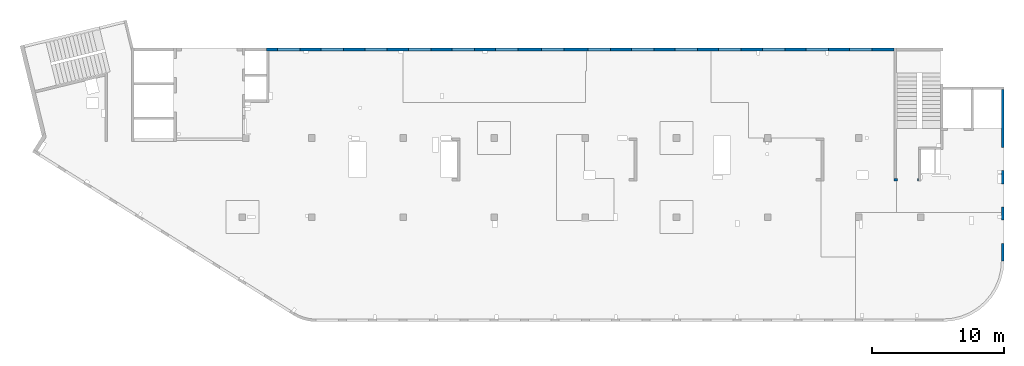
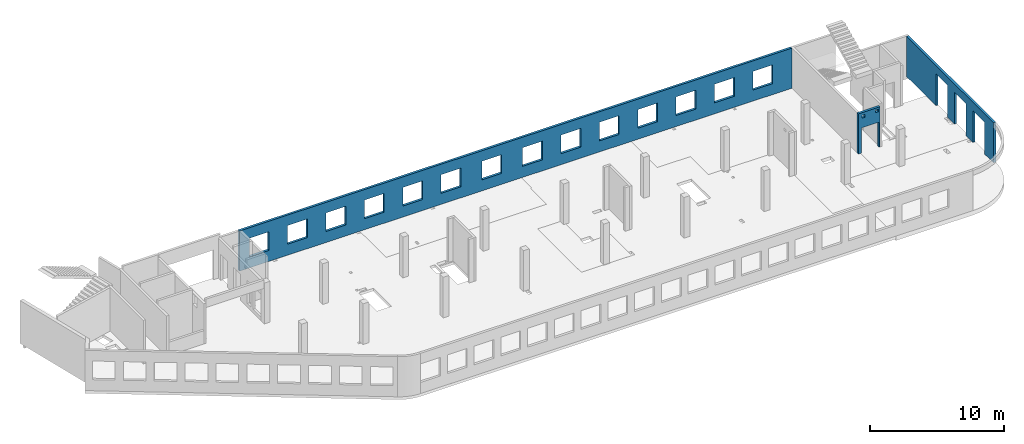
# One storey, part 6 of 6: 3 walls, 20 openings.
"""IFC4 building model written with IfcOpenShell, lengths in millimetres."""

from ifc_helpers import new_model, entity, si_unit, converted_unit, derived_unit, direction, frame, origin, place, context, subcontext, project, spatial, indexed_curve, outline, extrude, polygons, material, type_object, element, save


model = new_model("IFC4")

# Units and contexts
model_context = context("Model", 3, precision=0.01, world=origin(), true_north=direction((6.12303176911189e-17, 1.0)))
plan_context = context("Plan", 3, precision=0.01, world=origin(), true_north=direction((6.12303176911189e-17, 1.0)))
body_context = subcontext(model_context, "Body", "Model", "MODEL_VIEW")
ifc_project = project(units=[si_unit("LENGTHUNIT", "METRE", prefix="MILLI"), si_unit("AREAUNIT", "SQUARE_METRE"), si_unit("VOLUMEUNIT", "CUBIC_METRE"), converted_unit("PLANEANGLEUNIT", "DEGREE", entity("IfcRatioMeasure", 0.0174532925199433), si_unit("PLANEANGLEUNIT", "RADIAN"), dimensions=[0, 0, 0, 0, 0, 0, 0]), si_unit("MASSUNIT", "GRAM", prefix="KILO"), derived_unit("MASSDENSITYUNIT", [(si_unit("MASSUNIT", "GRAM", prefix="KILO"), 1), (si_unit("LENGTHUNIT", "METRE"), -3)]), derived_unit("MOMENTOFINERTIAUNIT", [(si_unit("LENGTHUNIT", "METRE"), 4)]), si_unit("TIMEUNIT", "SECOND"), si_unit("FREQUENCYUNIT", "HERTZ"), si_unit("THERMODYNAMICTEMPERATUREUNIT", "DEGREE_CELSIUS"), derived_unit("THERMALTRANSMITTANCEUNIT", [(si_unit("MASSUNIT", "GRAM", prefix="KILO"), 1), (si_unit("THERMODYNAMICTEMPERATUREUNIT", "KELVIN"), -1), (si_unit("TIMEUNIT", "SECOND"), -3)]), derived_unit("VOLUMETRICFLOWRATEUNIT", [(si_unit("LENGTHUNIT", "METRE"), 3), (si_unit("TIMEUNIT", "SECOND"), -1)]), derived_unit("MASSFLOWRATEUNIT", [(si_unit("MASSUNIT", "GRAM", prefix="KILO"), 1), (si_unit("TIMEUNIT", "SECOND"), -1)]), derived_unit("ROTATIONALFREQUENCYUNIT", [(si_unit("TIMEUNIT", "SECOND"), -1)]), si_unit("ELECTRICCURRENTUNIT", "AMPERE"), si_unit("ELECTRICVOLTAGEUNIT", "VOLT"), si_unit("POWERUNIT", "WATT"), si_unit("FORCEUNIT", "NEWTON", prefix="KILO"), si_unit("ILLUMINANCEUNIT", "LUX"), si_unit("LUMINOUSFLUXUNIT", "LUMEN"), si_unit("LUMINOUSINTENSITYUNIT", "CANDELA"), derived_unit("USERDEFINED", [(si_unit("MASSUNIT", "GRAM", prefix="KILO"), -1), (si_unit("LENGTHUNIT", "METRE"), -2), (si_unit("TIMEUNIT", "SECOND"), 3), (si_unit("LUMINOUSFLUXUNIT", "LUMEN"), 1)]), derived_unit("LINEARVELOCITYUNIT", [(si_unit("LENGTHUNIT", "METRE"), 1), (si_unit("TIMEUNIT", "SECOND"), -1)]), si_unit("PRESSUREUNIT", "PASCAL"), derived_unit("USERDEFINED", [(si_unit("LENGTHUNIT", "METRE"), -2), (si_unit("MASSUNIT", "GRAM", prefix="KILO"), 1), (si_unit("TIMEUNIT", "SECOND"), -2)]), derived_unit("LINEARFORCEUNIT", [(si_unit("MASSUNIT", "GRAM", prefix="KILO"), 1), (si_unit("LENGTHUNIT", "METRE"), 1), (si_unit("TIMEUNIT", "SECOND"), -2), (si_unit("LENGTHUNIT", "METRE"), -1)]), derived_unit("PLANARFORCEUNIT", [(si_unit("MASSUNIT", "GRAM", prefix="KILO"), 1), (si_unit("LENGTHUNIT", "METRE"), 1), (si_unit("TIMEUNIT", "SECOND"), -2), (si_unit("LENGTHUNIT", "METRE"), -2)])], contexts=[model_context, plan_context])

# Site, building, storey
site_placement = place(None, origin())
site = spatial("IfcSite", under=ifc_project, at=site_placement, CompositionType="ELEMENT")
building_placement = place(site_placement, origin())
building = spatial("IfcBuilding", under=site, at=building_placement, CompositionType="ELEMENT")
storey_placement = place(building_placement, frame((0.0, 0.0, 8100.0)))
storey = spatial("IfcBuildingStorey", under=building, at=storey_placement, CompositionType="ELEMENT", Elevation=8100.0)

# Wall, openings
ifc_material = material()
wall_type = type_object("IfcWallType", PredefinedType="STANDARD")
wall_1_placement = place(storey_placement, frame((73469.9994506836, 17369.9992263554, -150.0), z_axis=(0.0, 0.0, 1.0), x_axis=(0.0, -1.0, 0.0)))
wall_1 = element("IfcWall", 1, at=wall_1_placement, inside=storey, type_object=wall_type, material=ifc_material, PredefinedType="NOTDEFINED", context=body_context, shape_type="Tessellation", body=[
    polygons([(12970.0, -99.9999999999918, 0.0), (12970.0, -99.9999999999918, 3200.0), (12970.0, -99.9999999999918, 3650.0), (9560.00000000002, -99.9999999999877, 3650.0), (9360.00000000002, -99.999999999988, 3650.0), (7085.00000000004, -99.999999999991, 3650.0), (6485.00000000003, -99.9999999999918, 3650.0), (6320.00000000002, -99.999999999992, 3650.0), (6120.00000000002, -99.9999999999923, 3650.0), (0.0, -99.9999999999831, 3650.0), (0.0, -99.9999999999831, 0.0), (4394.99999999951, -99.9999999999946, 0.0), (4394.99999999951, -100.000000000315, 2900.0), (6144.99999999951, -100.000000000313, 2900.0), (6144.99999999951, -99.9999999999923, 0.0), (6319.99895780055, -99.999999999992, 0.0), (6485.00000000002, -99.9999999999918, 0.0), (7084.99895780057, -99.999999999991, 0.0), (7144.99999999951, -99.9999999999909, 0.0), (7144.99999999951, -100.000000000311, 2900.0), (8894.99999999951, -100.000000000309, 2900.0), (8894.99999999951, -99.9999999999886, 0.0), (9895.00000000005, -99.9999999999959, 0.0), (9895.00000000005, -99.9999999999959, 2900.0), (11645.0, -99.9999999999936, 2900.0), (11645.0, -99.9999999999936, 0.0), (12970.0, 100.000000000006, 3650.0), (12970.0, 100.000000000006, 3200.0), (12970.0, 100.000000000006, 0.0), (11645.0, 100.000000000004, 0.0), (11645.0, 100.000000000316, 2900.0), (9895.00000000005, 100.000000000314, 2900.0), (9895.00000000004, 100.000000000002, 0.0), (8894.99999999951, 100.000000000001, 0.0), (8894.99999999951, 100.000000000001, 2900.0), (7144.99999999951, 99.9999999999983, 2900.0), (7144.99999999951, 99.9999999999983, 0.0), (6144.99999999951, 99.9999999999969, 0.0), (6144.99999999951, 99.9999999999969, 2900.0), (4394.99999999951, 99.9999999999946, 2900.0), (4394.99999999951, 99.9999999999946, 0.0), (0.0, 100.000000000006, 0.0), (0.0, 100.000000000006, 3650.0)], [[[1, 2, 3, 4, 5, 6, 7, 8, 9, 10, 11, 12, 13, 14, 15, 16, 17, 18, 19, 20, 21, 22, 23, 24, 25, 26]], [[27, 28, 29, 30, 31, 32, 33, 34, 35, 36, 37, 38, 39, 40, 41, 42, 43]], [[11, 42, 41, 12]], [[3, 2, 1, 29, 28, 27]], [[10, 9, 8, 7, 6, 5, 4, 3, 27, 43]], [[11, 10, 43, 42]], [[24, 32, 31, 25]], [[32, 24, 23, 33]], [[25, 31, 30, 26]], [[35, 21, 20, 36]], [[21, 35, 34, 22]], [[36, 20, 19, 37]], [[39, 14, 13, 40]], [[14, 39, 38, 15]], [[40, 13, 12, 41]], [[37, 19, 18, 17, 16, 15, 38]], [[33, 23, 22, 34]], [[29, 1, 26, 30]]], closed=True),
])
opening_1_placement = place(wall_1_placement, frame((17369.9992263554, -73469.9994506836, 150.0), z_axis=(0.0, 0.0, 1.0), x_axis=(0.0, 1.0, 0.0)))
element("IfcOpeningElement", 2, at=opening_1_placement, cuts=wall_1, PredefinedType="OPENING", context=body_context, shape_type="SweptSolid", body=[
    extrude(outline(indexed_curve([(-1449.99999999999, -874.999999999999), (1449.99999999999, -874.999999999999), (1449.99999999999, 875.0), (-1449.99999999999, 875.0), (-1449.99999999999, -874.999999999999)], self_intersect=False)), frame((73369.9994506836, 6599.9992263554, 1300.0), z_axis=(1.0, 0.0, 0.0), x_axis=(0.0, 0.0, -1.0)), (0.0, 0.0, 1.0), 200.000000000968),
])
opening_2_placement = place(wall_1_placement, frame((17369.9992263554, -73469.9994506836, 150.0), z_axis=(0.0, 0.0, 1.0), x_axis=(0.0, 1.0, 0.0)))
element("IfcOpeningElement", 3, at=opening_2_placement, cuts=wall_1, PredefinedType="OPENING", context=body_context, shape_type="SweptSolid", body=[
    extrude(outline(indexed_curve([(-874.999999999999, -1449.99999999999), (874.999999999999, -1449.99999999999), (874.999999999999, 1450.0), (-874.999999999999, 1450.0), (-874.999999999999, -1449.99999999999)], self_intersect=False)), frame((73369.9994506826, 9349.99922635594, 1300.0), z_axis=(1.0, 0.0, 0.0), x_axis=(0.0, -1.0, 0.0)), (0.0, 0.0, 1.0), 200.000000000968),
])
opening_3_placement = place(wall_1_placement, frame((17369.9992263554, -73469.9994506836, 150.0), z_axis=(0.0, 0.0, 1.0), x_axis=(0.0, 1.0, 0.0)))
element("IfcOpeningElement", 4, at=opening_3_placement, cuts=wall_1, PredefinedType="OPENING", context=body_context, shape_type="SweptSolid", body=[
    extrude(outline(indexed_curve([(-875.0, -1449.99999999999), (874.999999999998, -1449.99999999999), (874.999999999998, 1450.0), (-875.0, 1450.0), (-875.0, -1449.99999999999)], self_intersect=False)), frame((73369.9994506826, 12099.9992263559, 1300.0), z_axis=(1.0, 0.0, 0.0), x_axis=(0.0, -1.0, 0.0)), (0.0, 0.0, 1.0), 200.000000000968),
])

wall_2_placement = place(storey_placement, frame((67080.0002685547, 10524.9992263555, -150.0), z_axis=(0.0, 0.0, 1.0), x_axis=(-1.0, 0.0, 0.0)))
wall_2 = element("IfcWall", 5, at=wall_2_placement, inside=storey, type_object=wall_type, material=ifc_material, PredefinedType="NOTDEFINED", context=body_context, shape_type="Tessellation", body=[
    polygons([(1849.99999999999, -100.000000000001, 3650.0), (1650.0, -100.000000000003, 3650.0), (-9.772240076716e-13, -100.000000000001, 3650.0), (-9.772240076716e-13, -100.000000000001, 0.0), (74.9999999999906, -100.000000000001, 0.0), (74.9999999999906, -100.000000000001, 2279.99999999805), (1575.0, -100.000000000001, 2279.99999999804), (1575.0, -100.000000000003, 0.0), (1650.0, -100.000000000003, 0.0), (1849.99999999999, -100.000000000001, 0.0), (125.000000000014, -100.000000000322, 3490.0), (375.000000000009, -100.000000000324, 3490.0), (375.000000000009, -100.000000000324, 3240.00000000001), (125.000000000014, -100.000000000322, 3240.00000000001), (1275.0, -100.000000000322, 3400.0), (1524.99999999999, -100.000000000322, 3400.0), (1524.99999999999, -100.000000000322, 3150.00000000001), (1275.0, -100.000000000322, 3150.00000000001), (-1.61109744921212e-12, 99.9999999999989, 3650.0), (1849.99999999999, 99.9999999999989, 3650.0), (1849.99999999999, 99.9999999999989, 0.0), (1575.0, 99.9999999999968, 0.0), (1575.0, 99.9999999999968, 2279.99999999804), (74.99999999999, 99.9999999999989, 2279.99999999805), (74.99999999999, 99.9999999999989, 0.0), (-1.61109744921212e-12, 99.9999999999989, 0.0), (375.000000000008, 99.9999999999968, 3490.0), (125.000000000013, 99.9999999999968, 3490.0), (125.000000000013, 99.9999999999968, 3240.00000000001), (375.000000000008, 99.9999999999968, 3240.00000000001), (1524.99999999999, 99.9999999999968, 3400.0), (1275.0, 99.9999999999989, 3400.0), (1275.0, 99.9999999999989, 3150.00000000001), (1524.99999999999, 99.9999999999968, 3150.00000000001)], [[[1, 2, 3, 4, 5, 6, 7, 8, 9, 10], [11, 12, 13, 14], [15, 16, 17, 18]], [[19, 20, 21, 22, 23, 24, 25, 26], [27, 28, 29, 30], [31, 32, 33, 34]], [[4, 26, 25, 5]], [[3, 2, 1, 20, 19]], [[4, 3, 19, 26]], [[1, 10, 21, 20]], [[12, 11, 28, 27]], [[12, 27, 30, 13]], [[13, 30, 29, 14]], [[28, 11, 14, 29]], [[16, 15, 32, 31]], [[16, 31, 34, 17]], [[17, 34, 33, 18]], [[32, 15, 18, 33]], [[6, 24, 23, 7]], [[7, 23, 22, 8]], [[24, 6, 5, 25]], [[21, 10, 9, 8, 22]]], closed=True),
])
opening_4_placement = place(wall_2_placement, frame((67080.0002685547, 10524.9992263555, 150.0), z_axis=(0.0, 0.0, 1.0), x_axis=(-1.0, 0.0, 0.0)))
element("IfcOpeningElement", 6, at=opening_4_placement, cuts=wall_2, PredefinedType="OPENING", context=body_context, shape_type="SweptSolid", body=[
    extrude(outline(indexed_curve([(-750.000000000003, -1139.99999999902), (749.999999999994, -1139.99999999902), (749.999999999994, 1139.99999999902), (-750.000000000003, 1139.99999999902), (-750.000000000003, -1139.99999999902)], self_intersect=False)), frame((66255.0002685547, 10724.9992263575, 990.0), z_axis=(0.0, -1.0, 0.0), x_axis=(-1.0, 0.0, 0.0)), (0.0, 0.0, 1.0), 400.000000001943),
])
opening_5_placement = place(wall_2_placement, frame((67080.0002685547, 10524.9992263555, 150.0), z_axis=(0.0, 0.0, 1.0), x_axis=(-1.0, 0.0, 0.0)))
element("IfcOpeningElement", 7, at=opening_5_placement, cuts=wall_2, PredefinedType="OPENING", context=body_context, shape_type="SweptSolid", body=[
    extrude(outline(indexed_curve([(-125.000000000006, -124.999999999993), (124.999999999998, -124.999999999993), (124.999999999998, 124.999999999993), (-125.000000000006, 124.999999999993), (-125.000000000006, -124.999999999993)], self_intersect=False)), frame((65680.0002685547, 10624.9992263565, 3125.0), z_axis=(0.0, -1.0, 0.0), x_axis=(-1.0, 0.0, 0.0)), (0.0, 0.0, 1.0), 200.000000000962),
])
opening_6_placement = place(wall_2_placement, frame((67080.0002685547, 10524.9992263555, 150.0), z_axis=(0.0, 0.0, 1.0), x_axis=(-1.0, 0.0, 0.0)))
element("IfcOpeningElement", 8, at=opening_6_placement, cuts=wall_2, PredefinedType="OPENING", context=body_context, shape_type="SweptSolid", body=[
    extrude(outline(indexed_curve([(-125.000000000006, -124.999999999993), (124.999999999998, -124.999999999993), (124.999999999998, 124.999999999993), (-125.000000000006, 124.999999999993), (-125.000000000006, -124.999999999993)], self_intersect=False)), frame((66830.0002685547, 10624.9992263565, 3215.0), z_axis=(0.0, -1.0, 0.0), x_axis=(-1.0, 0.0, 0.0)), (0.0, 0.0, 1.0), 200.000000000962),
])

wall_3_placement = place(storey_placement, frame((65230.0002685547, 20399.9998657227, -150.0), z_axis=(0.0, 0.0, 1.0), x_axis=(-1.0, 0.0, 0.0)))
wall_3 = element("IfcWall", 9, at=wall_3_placement, inside=storey, type_object=wall_type, material=ifc_material, PredefinedType="NOTDEFINED", context=body_context, shape_type="Tessellation", body=[
    polygons([(8.66293703438714e-12, -99.9999999999989, 0.0), (47505.0, -99.9999999999989, 0.0), (47505.0, -99.9999999999989, 3650.0), (8.66293703438714e-12, -99.9999999999989, 3650.0), (28460.0, -100.000000000319, 2700.0), (30160.0, -100.000000000319, 2700.0), (30160.0, -100.000000000319, 1000.00000000001), (28460.0, -100.000000000319, 1000.00000000001), (1660.00000000009, -100.000000000319, 2700.0), (3360.00000000009, -100.000000000319, 2700.0), (3360.00000000009, -100.000000000319, 1000.00000000001), (1660.00000000009, -100.000000000319, 1000.00000000001), (4960.00000000009, -100.000000000319, 2700.0), (6660.00000000009, -100.000000000319, 2700.0), (6660.00000000009, -100.000000000319, 1000.00000000001), (4960.00000000009, -100.000000000319, 1000.00000000001), (8260.00000000008, -100.000000000319, 2700.0), (9960.00000000008, -100.000000000319, 2700.0), (9960.00000000008, -100.000000000319, 1000.00000000001), (8260.00000000008, -100.000000000319, 1000.00000000001), (11560.0000000001, -100.000000000319, 2700.0), (13260.0000000001, -100.000000000319, 2700.0), (13260.0000000001, -100.000000000319, 1000.00000000001), (11560.0000000001, -100.000000000319, 1000.00000000001), (14860.0000000001, -100.000000000319, 2700.0), (16560.0000000001, -100.000000000319, 2700.0), (16560.0000000001, -100.000000000319, 1000.00000000001), (14860.0000000001, -100.000000000319, 1000.00000000001), (18160.0000000001, -100.000000000319, 2700.0), (19860.0000000001, -100.000000000319, 2700.0), (19860.0000000001, -100.000000000319, 1000.00000000001), (18160.0000000001, -100.000000000319, 1000.00000000001), (21460.0000000001, -100.000000000319, 2700.0), (23160.0000000001, -100.000000000319, 2700.0), (23160.0000000001, -100.000000000319, 1000.00000000001), (21460.0000000001, -100.000000000319, 1000.00000000001), (24960.0000000001, -100.000000000319, 2700.0), (26660.0000000001, -100.000000000319, 2700.0), (26660.0000000001, -100.000000000319, 1000.00000000001), (24960.0000000001, -100.000000000319, 1000.00000000001), (31760.0000000001, -100.000000000319, 2700.0), (33460.0000000001, -100.000000000319, 2700.0), (33460.0000000001, -100.000000000319, 1000.00000000001), (31760.0000000001, -100.000000000319, 1000.00000000001), (35060.0000000001, -100.000000000319, 2700.0), (36760.0000000001, -100.000000000319, 2700.0), (36760.0000000001, -100.000000000319, 1000.00000000001), (35060.0000000001, -100.000000000319, 1000.00000000001), (38360.0000000001, -100.000000000319, 2700.0), (40060.0000000001, -100.000000000319, 2700.0), (40060.0000000001, -100.000000000319, 1000.00000000001), (38360.0000000001, -100.000000000319, 1000.00000000001), (41660.0, -100.000000000319, 2700.0), (43360.0, -100.000000000319, 2700.0), (43360.0, -100.000000000319, 1000.00000000001), (41660.0, -100.000000000319, 1000.00000000001), (44960.0, -100.000000000319, 2700.0), (46660.0, -100.000000000319, 2700.0), (46660.0, -100.000000000319, 1000.00000000001), (44960.0, -100.000000000319, 1000.00000000001), (8.66293703438714e-12, 99.9999999999989, 0.0), (8.66293703438714e-12, 99.9999999999989, 3650.0), (47305.0, 99.9999999999989, 3650.0), (47505.0, 99.9999999999989, 3650.0), (47505.0, 99.9999999999989, 0.0), (47305.0, 99.9999999999989, 0.0), (44660.0000000001, 99.9999999999989, 0.0), (44360.0000000001, 99.9999999999989, 0.0), (37460.0000000001, 99.9999999999989, 0.0), (37160.0000000001, 99.9999999999989, 0.0), (10360.0000000001, 99.9999999999989, 0.0), (10160.0000000001, 99.9999999999989, 0.0), (5150.00000000013, 99.9999999999989, 0.0), (4950.0000000001, 99.9999999999989, 0.0), (30160.0, 99.9999999999989, 2700.0), (28460.0, 99.9999999999989, 2700.0), (28460.0, 99.9999999999989, 1000.00000000001), (30160.0, 99.9999999999989, 1000.00000000001), (3360.00000000009, 99.9999999999989, 2700.0), (1660.00000000009, 99.9999999999989, 2700.0), (1660.00000000009, 99.9999999999989, 1000.00000000001), (3360.00000000009, 99.9999999999989, 1000.00000000001), (6660.00000000009, 99.9999999999989, 2700.0), (4960.00000000009, 99.9999999999989, 2700.0), (4960.00000000009, 99.9999999999989, 1000.00000000001), (6660.00000000009, 99.9999999999989, 1000.00000000001), (9960.00000000008, 99.9999999999989, 2700.0), (8260.00000000008, 99.9999999999989, 2700.0), (8260.00000000008, 99.9999999999989, 1000.00000000001), (9960.00000000008, 99.9999999999989, 1000.00000000001), (13260.0000000001, 99.9999999999989, 2700.0), (11560.0000000001, 99.9999999999989, 2700.0), (11560.0000000001, 99.9999999999989, 1000.00000000001), (13260.0000000001, 99.9999999999989, 1000.00000000001), (16560.0000000001, 99.9999999999989, 2700.0), (14860.0000000001, 99.9999999999989, 2700.0), (14860.0000000001, 99.9999999999989, 1000.00000000001), (16560.0000000001, 99.9999999999989, 1000.00000000001), (19860.0000000001, 99.9999999999989, 2700.0), (18160.0000000001, 99.9999999999989, 2700.0), (18160.0000000001, 99.9999999999989, 1000.00000000001), (19860.0000000001, 99.9999999999989, 1000.00000000001), (23160.0000000001, 99.9999999999989, 2700.0), (21460.0000000001, 99.9999999999989, 2700.0), (21460.0000000001, 99.9999999999989, 1000.00000000001), (23160.0000000001, 99.9999999999989, 1000.00000000001), (26660.0000000001, 99.9999999999989, 2700.0), (24960.0000000001, 99.9999999999989, 2700.0), (24960.0000000001, 99.9999999999989, 1000.00000000001), (26660.0000000001, 99.9999999999989, 1000.00000000001), (33460.0000000001, 99.9999999999989, 2700.0), (31760.0000000001, 99.9999999999989, 2700.0), (31760.0000000001, 99.9999999999989, 1000.00000000001), (33460.0000000001, 99.9999999999989, 1000.00000000001), (36760.0000000001, 99.9999999999989, 2700.0), (35060.0000000001, 99.9999999999989, 2700.0), (35060.0000000001, 99.9999999999989, 1000.00000000001), (36760.0000000001, 99.9999999999989, 1000.00000000001), (40060.0000000001, 99.9999999999989, 2700.0), (38360.0000000001, 99.9999999999989, 2700.0), (38360.0000000001, 99.9999999999989, 1000.00000000001), (40060.0000000001, 99.9999999999989, 1000.00000000001), (43360.0, 99.9999999999989, 2700.0), (41660.0, 99.9999999999989, 2700.0), (41660.0, 99.9999999999989, 1000.00000000001), (43360.0, 99.9999999999989, 1000.00000000001), (46660.0, 99.9999999999989, 2700.0), (44960.0, 99.9999999999989, 2700.0), (44960.0, 99.9999999999989, 1000.00000000001), (46660.0, 99.9999999999989, 1000.00000000001)], [[[1, 2, 3, 4], [5, 6, 7, 8], [9, 10, 11, 12], [13, 14, 15, 16], [17, 18, 19, 20], [21, 22, 23, 24], [25, 26, 27, 28], [29, 30, 31, 32], [33, 34, 35, 36], [37, 38, 39, 40], [41, 42, 43, 44], [45, 46, 47, 48], [49, 50, 51, 52], [53, 54, 55, 56], [57, 58, 59, 60]], [[61, 62, 63, 64, 65, 66, 67, 68, 69, 70, 71, 72, 73, 74], [75, 76, 77, 78], [79, 80, 81, 82], [83, 84, 85, 86], [87, 88, 89, 90], [91, 92, 93, 94], [95, 96, 97, 98], [99, 100, 101, 102], [103, 104, 105, 106], [107, 108, 109, 110], [111, 112, 113, 114], [115, 116, 117, 118], [119, 120, 121, 122], [123, 124, 125, 126], [127, 128, 129, 130]], [[2, 1, 61, 74, 73, 72, 71, 70, 69, 68, 67, 66, 65]], [[4, 3, 64, 63, 62]], [[1, 4, 62, 61]], [[3, 2, 65, 64]], [[6, 5, 76, 75]], [[6, 75, 78, 7]], [[7, 78, 77, 8]], [[76, 5, 8, 77]], [[10, 9, 80, 79]], [[10, 79, 82, 11]], [[11, 82, 81, 12]], [[80, 9, 12, 81]], [[14, 13, 84, 83]], [[14, 83, 86, 15]], [[15, 86, 85, 16]], [[84, 13, 16, 85]], [[18, 17, 88, 87]], [[18, 87, 90, 19]], [[19, 90, 89, 20]], [[88, 17, 20, 89]], [[22, 21, 92, 91]], [[22, 91, 94, 23]], [[23, 94, 93, 24]], [[92, 21, 24, 93]], [[26, 25, 96, 95]], [[26, 95, 98, 27]], [[27, 98, 97, 28]], [[96, 25, 28, 97]], [[30, 29, 100, 99]], [[30, 99, 102, 31]], [[31, 102, 101, 32]], [[100, 29, 32, 101]], [[34, 33, 104, 103]], [[34, 103, 106, 35]], [[35, 106, 105, 36]], [[104, 33, 36, 105]], [[38, 37, 108, 107]], [[38, 107, 110, 39]], [[39, 110, 109, 40]], [[108, 37, 40, 109]], [[42, 41, 112, 111]], [[42, 111, 114, 43]], [[43, 114, 113, 44]], [[112, 41, 44, 113]], [[46, 45, 116, 115]], [[46, 115, 118, 47]], [[47, 118, 117, 48]], [[116, 45, 48, 117]], [[50, 49, 120, 119]], [[50, 119, 122, 51]], [[51, 122, 121, 52]], [[120, 49, 52, 121]], [[54, 53, 124, 123]], [[54, 123, 126, 55]], [[55, 126, 125, 56]], [[124, 53, 56, 125]], [[58, 57, 128, 127]], [[58, 127, 130, 59]], [[59, 130, 129, 60]], [[128, 57, 60, 129]]], closed=True),
])
opening_7_placement = place(wall_3_placement, frame((65230.0002685547, 20399.9998657227, 150.0), z_axis=(0.0, 0.0, 1.0), x_axis=(-1.0, 0.0, 0.0)))
element("IfcOpeningElement", 10, at=opening_7_placement, cuts=wall_3, PredefinedType="OPENING", context=body_context, shape_type="SweptSolid", body=[
    extrude(outline(indexed_curve([(-850.000000000002, -849.999999999995), (850.0, -849.999999999995), (850.0, 849.999999999993), (-850.000000000002, 849.999999999993), (-850.000000000002, -849.999999999995)], self_intersect=False)), frame((19420.0002685547, 20499.9998657236, 1700.0), z_axis=(0.0, -1.0, 0.0), x_axis=(-1.0, 0.0, 0.0)), (0.0, 0.0, 1.0), 200.000000000959),
])
opening_8_placement = place(wall_3_placement, frame((65230.0002685547, 20399.9998657227, 150.0), z_axis=(0.0, 0.0, 1.0), x_axis=(-1.0, 0.0, 0.0)))
element("IfcOpeningElement", 11, at=opening_8_placement, cuts=wall_3, PredefinedType="OPENING", context=body_context, shape_type="SweptSolid", body=[
    extrude(outline(indexed_curve([(-850.000000000002, -849.999999999995), (849.999999999997, -849.999999999995), (849.999999999997, 849.999999999993), (-850.000000000002, 849.999999999993), (-850.000000000002, -849.999999999995)], self_intersect=False)), frame((22720.0002685547, 20499.9998657236, 1700.0), z_axis=(0.0, -1.0, 0.0), x_axis=(-1.0, 0.0, 0.0)), (0.0, 0.0, 1.0), 200.000000000959),
])
opening_9_placement = place(wall_3_placement, frame((65230.0002685547, 20399.9998657227, 150.0), z_axis=(0.0, 0.0, 1.0), x_axis=(-1.0, 0.0, 0.0)))
element("IfcOpeningElement", 12, at=opening_9_placement, cuts=wall_3, PredefinedType="OPENING", context=body_context, shape_type="SweptSolid", body=[
    extrude(outline(indexed_curve([(-850.000000000002, -849.999999999995), (849.999999999997, -849.999999999995), (849.999999999997, 849.999999999993), (-850.000000000002, 849.999999999993), (-850.000000000002, -849.999999999995)], self_intersect=False)), frame((26020.0002685547, 20499.9998657236, 1700.0), z_axis=(0.0, -1.0, 0.0), x_axis=(-1.0, 0.0, 0.0)), (0.0, 0.0, 1.0), 200.000000000959),
])
opening_10_placement = place(wall_3_placement, frame((65230.0002685547, 20399.9998657227, 150.0), z_axis=(0.0, 0.0, 1.0), x_axis=(-1.0, 0.0, 0.0)))
element("IfcOpeningElement", 13, at=opening_10_placement, cuts=wall_3, PredefinedType="OPENING", context=body_context, shape_type="SweptSolid", body=[
    extrude(outline(indexed_curve([(-850.000000000002, -849.999999999995), (849.999999999997, -849.999999999995), (849.999999999997, 849.999999999993), (-850.000000000002, 849.999999999993), (-850.000000000002, -849.999999999995)], self_intersect=False)), frame((29320.0002685547, 20499.9998657236, 1700.0), z_axis=(0.0, -1.0, 0.0), x_axis=(-1.0, 0.0, 0.0)), (0.0, 0.0, 1.0), 200.000000000959),
])
opening_11_placement = place(wall_3_placement, frame((65230.0002685547, 20399.9998657227, 150.0), z_axis=(0.0, 0.0, 1.0), x_axis=(-1.0, 0.0, 0.0)))
element("IfcOpeningElement", 14, at=opening_11_placement, cuts=wall_3, PredefinedType="OPENING", context=body_context, shape_type="SweptSolid", body=[
    extrude(outline(indexed_curve([(-849.999999999997, -849.999999999995), (850.000000000002, -849.999999999995), (850.000000000002, 849.999999999993), (-849.999999999997, 849.999999999993), (-849.999999999997, -849.999999999995)], self_intersect=False)), frame((32620.0002685547, 20499.9998657236, 1700.0), z_axis=(0.0, -1.0, 0.0), x_axis=(-1.0, 0.0, 0.0)), (0.0, 0.0, 1.0), 200.000000000959),
])
opening_12_placement = place(wall_3_placement, frame((65230.0002685547, 20399.9998657227, 150.0), z_axis=(0.0, 0.0, 1.0), x_axis=(-1.0, 0.0, 0.0)))
element("IfcOpeningElement", 15, at=opening_12_placement, cuts=wall_3, PredefinedType="OPENING", context=body_context, shape_type="SweptSolid", body=[
    extrude(outline(indexed_curve([(-849.999999999997, -849.999999999995), (850.000000000006, -849.999999999995), (850.000000000006, 849.999999999993), (-849.999999999997, 849.999999999993), (-849.999999999997, -849.999999999995)], self_intersect=False)), frame((39420.0002685547, 20499.9998657236, 1700.0), z_axis=(0.0, -1.0, 0.0), x_axis=(-1.0, 0.0, 0.0)), (0.0, 0.0, 1.0), 200.000000000959),
])
opening_13_placement = place(wall_3_placement, frame((65230.0002685547, 20399.9998657227, 150.0), z_axis=(0.0, 0.0, 1.0), x_axis=(-1.0, 0.0, 0.0)))
element("IfcOpeningElement", 16, at=opening_13_placement, cuts=wall_3, PredefinedType="OPENING", context=body_context, shape_type="SweptSolid", body=[
    extrude(outline(indexed_curve([(-850.000000000006, -849.999999999995), (849.999999999997, -849.999999999995), (849.999999999997, 849.999999999993), (-850.000000000006, 849.999999999993), (-850.000000000006, -849.999999999995)], self_intersect=False)), frame((42920.0002685547, 20499.9998657236, 1700.0), z_axis=(0.0, -1.0, 0.0), x_axis=(-1.0, 0.0, 0.0)), (0.0, 0.0, 1.0), 200.000000000959),
])
opening_14_placement = place(wall_3_placement, frame((65230.0002685547, 20399.9998657227, 150.0), z_axis=(0.0, 0.0, 1.0), x_axis=(-1.0, 0.0, 0.0)))
element("IfcOpeningElement", 17, at=opening_14_placement, cuts=wall_3, PredefinedType="OPENING", context=body_context, shape_type="SweptSolid", body=[
    extrude(outline(indexed_curve([(-849.999999999997, -849.999999999995), (850.000000000006, -849.999999999995), (850.000000000006, 849.999999999993), (-849.999999999997, 849.999999999993), (-849.999999999997, -849.999999999995)], self_intersect=False)), frame((46220.0002685547, 20499.9998657236, 1700.0), z_axis=(0.0, -1.0, 0.0), x_axis=(-1.0, 0.0, 0.0)), (0.0, 0.0, 1.0), 200.000000000959),
])
opening_15_placement = place(wall_3_placement, frame((65230.0002685547, 20399.9998657227, 150.0), z_axis=(0.0, 0.0, 1.0), x_axis=(-1.0, 0.0, 0.0)))
element("IfcOpeningElement", 18, at=opening_15_placement, cuts=wall_3, PredefinedType="OPENING", context=body_context, shape_type="SweptSolid", body=[
    extrude(outline(indexed_curve([(-849.999999999997, -849.999999999995), (850.000000000006, -849.999999999995), (850.000000000006, 849.999999999993), (-849.999999999997, 849.999999999993), (-849.999999999997, -849.999999999995)], self_intersect=False)), frame((49520.0002685547, 20499.9998657236, 1700.0), z_axis=(0.0, -1.0, 0.0), x_axis=(-1.0, 0.0, 0.0)), (0.0, 0.0, 1.0), 200.000000000959),
])
opening_16_placement = place(wall_3_placement, frame((65230.0002685547, 20399.9998657227, 150.0), z_axis=(0.0, 0.0, 1.0), x_axis=(-1.0, 0.0, 0.0)))
element("IfcOpeningElement", 19, at=opening_16_placement, cuts=wall_3, PredefinedType="OPENING", context=body_context, shape_type="SweptSolid", body=[
    extrude(outline(indexed_curve([(-849.999999999997, -849.999999999995), (850.000000000006, -849.999999999995), (850.000000000006, 849.999999999993), (-849.999999999997, 849.999999999993), (-849.999999999997, -849.999999999995)], self_intersect=False)), frame((52820.0002685547, 20499.9998657236, 1700.0), z_axis=(0.0, -1.0, 0.0), x_axis=(-1.0, 0.0, 0.0)), (0.0, 0.0, 1.0), 200.000000000959),
])
opening_17_placement = place(wall_3_placement, frame((65230.0002685547, 20399.9998657227, 150.0), z_axis=(0.0, 0.0, 1.0), x_axis=(-1.0, 0.0, 0.0)))
element("IfcOpeningElement", 20, at=opening_17_placement, cuts=wall_3, PredefinedType="OPENING", context=body_context, shape_type="SweptSolid", body=[
    extrude(outline(indexed_curve([(-849.999999999997, -849.999999999995), (850.000000000006, -849.999999999995), (850.000000000006, 849.999999999993), (-849.999999999997, 849.999999999993), (-849.999999999997, -849.999999999995)], self_intersect=False)), frame((56120.0002685547, 20499.9998657236, 1700.0), z_axis=(0.0, -1.0, 0.0), x_axis=(-1.0, 0.0, 0.0)), (0.0, 0.0, 1.0), 200.000000000959),
])
opening_18_placement = place(wall_3_placement, frame((65230.0002685547, 20399.9998657227, 150.0), z_axis=(0.0, 0.0, 1.0), x_axis=(-1.0, 0.0, 0.0)))
element("IfcOpeningElement", 21, at=opening_18_placement, cuts=wall_3, PredefinedType="OPENING", context=body_context, shape_type="SweptSolid", body=[
    extrude(outline(indexed_curve([(-849.999999999997, -849.999999999995), (850.000000000006, -849.999999999995), (850.000000000006, 849.999999999993), (-849.999999999997, 849.999999999993), (-849.999999999997, -849.999999999995)], self_intersect=False)), frame((59420.0002685547, 20499.9998657236, 1700.0), z_axis=(0.0, -1.0, 0.0), x_axis=(-1.0, 0.0, 0.0)), (0.0, 0.0, 1.0), 200.000000000959),
])
opening_19_placement = place(wall_3_placement, frame((65230.0002685547, 20399.9998657227, 150.0), z_axis=(0.0, 0.0, 1.0), x_axis=(-1.0, 0.0, 0.0)))
element("IfcOpeningElement", 22, at=opening_19_placement, cuts=wall_3, PredefinedType="OPENING", context=body_context, shape_type="SweptSolid", body=[
    extrude(outline(indexed_curve([(-849.999999999997, -849.999999999995), (850.000000000006, -849.999999999995), (850.000000000006, 849.999999999993), (-849.999999999997, 849.999999999993), (-849.999999999997, -849.999999999995)], self_intersect=False)), frame((62720.0002685547, 20499.9998657236, 1700.0), z_axis=(0.0, -1.0, 0.0), x_axis=(-1.0, 0.0, 0.0)), (0.0, 0.0, 1.0), 200.000000000959),
])
opening_20_placement = place(wall_3_placement, frame((65230.0002685547, 20399.9998657227, 150.0), z_axis=(0.0, 0.0, 1.0), x_axis=(-1.0, 0.0, 0.0)))
element("IfcOpeningElement", 23, at=opening_20_placement, cuts=wall_3, PredefinedType="OPENING", context=body_context, shape_type="SweptSolid", body=[
    extrude(outline(indexed_curve([(-849.999999999997, -849.999999999995), (850.000000000002, -849.999999999995), (850.000000000002, 849.999999999993), (-849.999999999997, 849.999999999993), (-849.999999999997, -849.999999999995)], self_intersect=False)), frame((35920.0002685547, 20499.9998657236, 1700.0), z_axis=(0.0, -1.0, 0.0), x_axis=(-1.0, 0.0, 0.0)), (0.0, 0.0, 1.0), 200.000000000959),
])

save(model, "model.ifc")
